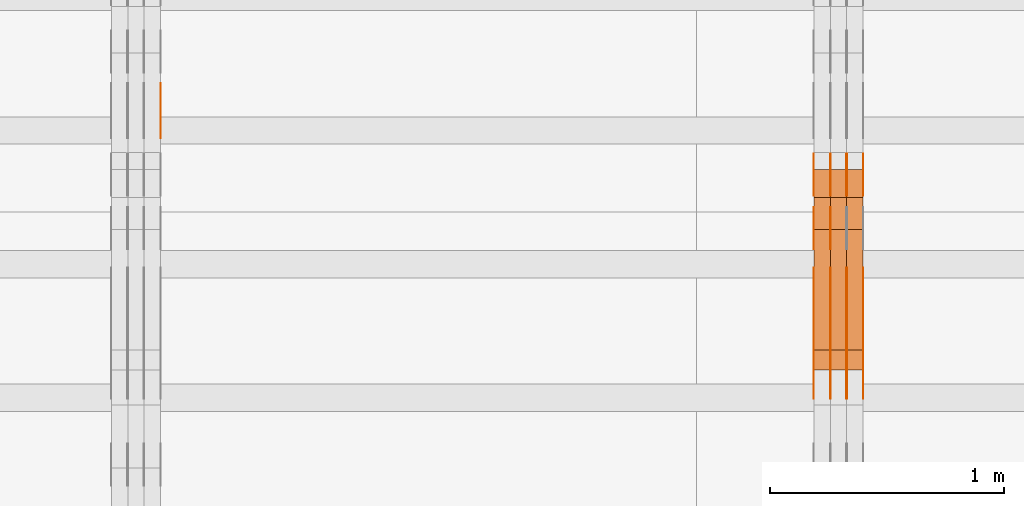
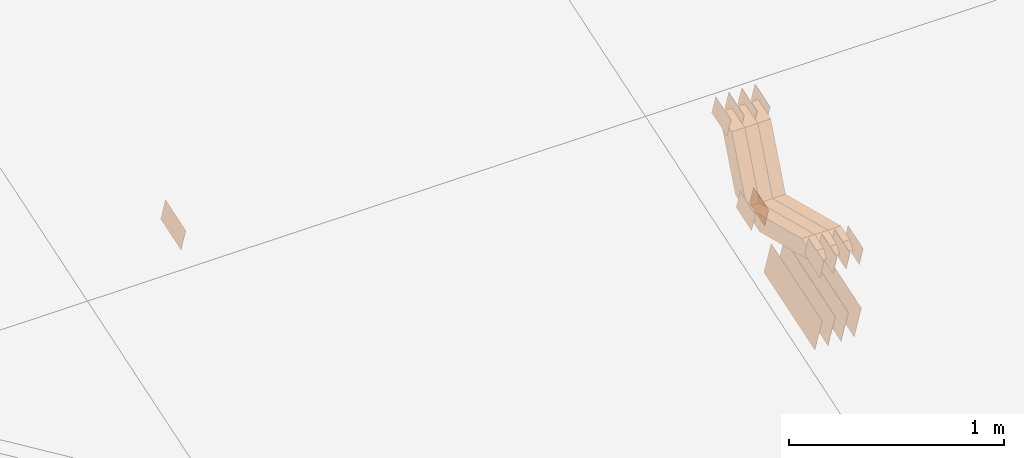
# One storey, part 259 of 385: 28 proxies.
"""IFC2X3 building model written with IfcOpenShell, lengths in millimetres."""

import ifcopenshell
import ifcopenshell.guid

model = None  # the IFC model being written
_history = None  # IfcOwnerHistory: only IFC2X3 demands one
_inside = {}  # id of a spatial element -> (the spatial element, [elements in it])
_under = {}  # id of a project, library or spatial element -> (it, [spatial elements below it])
_declared = {}  # id of a project -> (the project, [libraries it declares])
_typed = {}  # id of a type object -> (the type object, [elements of that type])
_made_of = {}  # id of a material, layer set ... -> (it, [elements and type objects made of it])


def new_model(schema):
    """Start an empty IFC model of exactly this schema.

    Asked for "IFC4X3", IfcOpenShell would pick the latest addendum, in which some entities
    have other attributes; the version numbers below select the first issue.
    IFC2X3 requires an IfcOwnerHistory on every rooted entity: one is made here for all.
    """
    global model, _history
    if schema == "IFC4X3":
        model = ifcopenshell.file(schema_version=(4, 3, 0, 0))
    else:
        model = ifcopenshell.file(schema=schema)
    _inside.clear()
    _under.clear()
    _declared.clear()
    _typed.clear()
    _made_of.clear()
    _history = None
    if model.schema == "IFC2X3":
        org = make("IfcOrganization", Name="unknown")
        user = make(
            "IfcPersonAndOrganization",
            ThePerson=make("IfcPerson", FamilyName="unknown"),
            TheOrganization=org,
        )
        app = make(
            "IfcApplication",
            ApplicationDeveloper=org,
            Version="unknown",
            ApplicationFullName="unknown",
            ApplicationIdentifier="unknown",
        )
        _history = make(
            "IfcOwnerHistory",
            OwningUser=user,
            OwningApplication=app,
            ChangeAction="ADDED",
            CreationDate=0,
        )
    return model


def make(cls, **values):
    """One entity of the class cls with the attributes given. An attribute that is None is left unset."""
    return model.create_entity(
        cls, **{name: value for name, value in values.items() if value is not None}
    )


def entity(cls, *values):
    """Any entity or typed value of the class cls, its attributes in the order of the schema. None: left unset."""
    e = model.create_entity(cls)
    for i, value in enumerate(values):
        if value is not None:
            e[i] = value
    return e


def rooted(cls, **values):
    """An entity with a GlobalId (a new one), such as an element, a storey or a relation."""
    return make(cls, GlobalId=ifcopenshell.guid.new(), OwnerHistory=_history, **values)


def si_unit(unit_type, name, prefix=None):
    """IfcSIUnit, for example si_unit("LENGTHUNIT", "METRE", prefix="MILLI")."""
    return make("IfcSIUnit", UnitType=unit_type, Prefix=prefix, Name=name)


def converted_unit(unit_type, name, factor, base, dimensions=None, offset=None):
    """IfcConversionBasedUnit, such as the inch: factor (a typed value) times the base unit."""
    return make(
        "IfcConversionBasedUnit"
        if offset is None
        else "IfcConversionBasedUnitWithOffset",
        ConversionOffset=offset,
        Dimensions=None
        if dimensions is None
        else entity("IfcDimensionalExponents", *dimensions),
        UnitType=unit_type,
        Name=name,
        ConversionFactor=make(
            "IfcMeasureWithUnit", ValueComponent=factor, UnitComponent=base
        ),
    )


def derived_unit(unit_type, elements):
    """IfcDerivedUnit: a product of units, each with its exponent."""
    return make(
        "IfcDerivedUnit",
        Elements=[
            make("IfcDerivedUnitElement", Unit=unit, Exponent=power)
            for unit, power in elements
        ],
        UnitType=unit_type,
    )


def assignment(units):
    """IfcUnitAssignment: the units of a project."""
    return None if units is None else make("IfcUnitAssignment", Units=units)


def point(xyz):
    """IfcCartesianPoint."""
    return None if xyz is None else make("IfcCartesianPoint", Coordinates=xyz)


def direction(xyz):
    """IfcDirection."""
    return None if xyz is None else make("IfcDirection", DirectionRatios=xyz)


def frame(location, z_axis=None, x_axis=None):
    """IfcAxis2Placement3D, a coordinate frame: its origin and axes. An axis left out is left unset."""
    return make(
        "IfcAxis2Placement3D",
        Location=point(location),
        Axis=direction(z_axis),
        RefDirection=direction(x_axis),
    )


def origin():
    """The frame at (0, 0, 0) with its axes left unset."""
    return frame((0.0, 0.0, 0.0))


def place(relative_to, where):
    """IfcLocalPlacement: puts the frame where relative to a parent placement (None: the world)."""
    return make(
        "IfcLocalPlacement", PlacementRelTo=relative_to, RelativePlacement=where
    )


def context(
    kind, dimensions, precision=None, world=None, true_north=None, identifier=None
):
    """IfcGeometricRepresentationContext, for example the 3D "Model" context."""
    return make(
        "IfcGeometricRepresentationContext",
        ContextIdentifier=identifier,
        ContextType=kind,
        CoordinateSpaceDimension=dimensions,
        Precision=precision,
        WorldCoordinateSystem=world,
        TrueNorth=true_north,
    )


def subcontext(parent, identifier, kind, view, scale=None):
    """IfcGeometricRepresentationSubContext, for example "Body" below "Model"."""
    return make(
        "IfcGeometricRepresentationSubContext",
        ContextIdentifier=identifier,
        ContextType=kind,
        ParentContext=parent,
        TargetScale=scale,
        TargetView=view,
    )


def project(units=None, contexts=None):
    """IfcProject with its units and contexts."""
    return rooted(
        "IfcProject",
        Name="project",
        RepresentationContexts=contexts,
        UnitsInContext=assignment(units),
    )


def spatial(cls, under=None, at=None, **own):
    """A site, building, storey or space (cls), placed at a placement, below another one or the project."""
    s = rooted(cls, ObjectPlacement=at, **own)
    if under is not None:
        _under.setdefault(under.id(), (under, []))[1].append(s)
    return s


def polyline(points):
    """IfcPolyline through the points."""
    return make("IfcPolyline", Points=[point(p) for p in points])


def outline(outer, holes=None, kind="AREA"):
    """IfcArbitraryClosedProfileDef: a profile drawn as a closed curve; with holes, ...WithVoids."""
    if holes is None:
        return make("IfcArbitraryClosedProfileDef", ProfileType=kind, OuterCurve=outer)
    return make(
        "IfcArbitraryProfileDefWithVoids",
        ProfileType=kind,
        OuterCurve=outer,
        InnerCurves=holes,
    )


def extrude(swept, where, along, depth):
    """IfcExtrudedAreaSolid: the profile swept, set in the frame where, extruded along a direction by depth."""
    return make(
        "IfcExtrudedAreaSolid",
        SweptArea=swept,
        Position=where,
        ExtrudedDirection=direction(along),
        Depth=depth,
    )


def shape(context_of_items, identifier, shape_type, items):
    """IfcShapeRepresentation: the items that make up one representation, for example the "Body"."""
    return make(
        "IfcShapeRepresentation",
        ContextOfItems=context_of_items,
        RepresentationIdentifier=identifier,
        RepresentationType=shape_type,
        Items=items,
    )


def source(mapping_origin, context_of_items, identifier, shape_type, items):
    """IfcRepresentationMap: a shape defined once, which mapped items show again and again."""
    return make(
        "IfcRepresentationMap",
        MappingOrigin=mapping_origin,
        MappedRepresentation=shape(context_of_items, identifier, shape_type, items),
    )


def transform(
    local_origin,
    x_axis=None,
    y_axis=None,
    z_axis=None,
    scale=None,
    scale2=None,
    scale3=None,
    uniform=True,
):
    """IfcCartesianTransformationOperator3D, or its non-uniform kind. x_axis, y_axis, z_axis: its Axis1, 2, 3."""
    if uniform:
        return make(
            "IfcCartesianTransformationOperator3D",
            Axis1=direction(x_axis),
            Axis2=direction(y_axis),
            LocalOrigin=point(local_origin),
            Scale=scale,
            Axis3=direction(z_axis),
        )
    return make(
        "IfcCartesianTransformationOperator3DnonUniform",
        Axis1=direction(x_axis),
        Axis2=direction(y_axis),
        LocalOrigin=point(local_origin),
        Scale=scale,
        Axis3=direction(z_axis),
        Scale2=scale2,
        Scale3=scale3,
    )


def mapped(mapping_source, mapping_target):
    """IfcMappedItem: shows the shape of a source again, moved by a transform."""
    return make(
        "IfcMappedItem", MappingSource=mapping_source, MappingTarget=mapping_target
    )


def material(Name=None, Category=None):
    """IfcMaterial."""
    return make("IfcMaterial", Name=Name, Category=Category)


def made_of(thing, what):
    """Note that an element or type object is made of a material, layer set ...; save() writes the relation."""
    if what is not None:
        _made_of.setdefault(what.id(), (what, []))[1].append(thing)
    return thing


def type_object(cls, material=None, **own):
    """A type object (cls), such as IfcWallType, which elements share."""
    return made_of(rooted(cls, **own), material)


def type_shapes(of_type, sources):
    """Give a type object the sources (RepresentationMaps) that its elements show as mapped items."""
    of_type.RepresentationMaps = sources


def element(
    cls,
    number,
    at=None,
    inside=None,
    cuts=None,
    type_object=None,
    material=None,
    context=None,
    identifier="Body",
    shape_type=None,
    held_by="IfcProductDefinitionShape",
    body=None,
    shapes=None,
    **own,
):
    """One element of the class cls, such as IfcWall. Its Tag is "e" and its number.

    at: its placement. inside: the storey or other place that contains it. cuts: it is an
    opening in that element (IfcRelVoidsElement). A single representation is given by context,
    identifier, shape_type and body (its items); several are given by shapes. held_by: the class
    of the entity that holds the representations. save() writes the other relations.
    """
    e = rooted(cls, Tag="e%d" % number, ObjectPlacement=at, **own)
    if body is not None:
        shapes = [shape(context, identifier, shape_type, body)]
    if shapes is not None:
        e.Representation = make(held_by, Representations=shapes)
    if inside is not None:
        _inside.setdefault(inside.id(), (inside, []))[1].append(e)
    if cuts is not None:
        rooted(
            "IfcRelVoidsElement", RelatingBuildingElement=cuts, RelatedOpeningElement=e
        )
    if type_object is not None:
        _typed.setdefault(type_object.id(), (type_object, []))[1].append(e)
    return made_of(e, material)


def aggregate(whole, parts):
    """IfcRelAggregates: a whole, such as a stair, and the parts it consists of."""
    return rooted("IfcRelAggregates", RelatingObject=whole, RelatedObjects=parts)


def save(model, path):
    """Write the relations noted so far, then the file.

    IfcRelAggregates (storeys below a building ...), IfcRelContainedInSpatialStructure (elements
    in a storey), IfcRelDefinesByType, IfcRelAssociatesMaterial and IfcRelDeclares: one each for
    every whole, place, type object, material and project.
    """
    for whole, parts in _under.values():
        aggregate(whole, parts)
    for where, things in _inside.values():
        rooted(
            "IfcRelContainedInSpatialStructure",
            RelatedElements=things,
            RelatingStructure=where,
        )
    for kind, things in _typed.values():
        rooted("IfcRelDefinesByType", RelatedObjects=things, RelatingType=kind)
    for what, things in _made_of.values():
        rooted("IfcRelAssociatesMaterial", RelatedObjects=things, RelatingMaterial=what)
    for by, libraries in _declared.values():
        rooted("IfcRelDeclares", RelatingContext=by, RelatedDefinitions=libraries)
    model.write(path)


model = new_model("IFC2X3")

# Units and contexts
model_context = context("Model", 3, precision=0.01, world=origin(), true_north=direction((6.12303176911189e-17, 1.0)))
body_context = subcontext(model_context, "Body", "Model", "MODEL_VIEW")
ifc_project = project(units=[si_unit("LENGTHUNIT", "METRE", prefix="MILLI"), si_unit("AREAUNIT", "SQUARE_METRE"), si_unit("VOLUMEUNIT", "CUBIC_METRE"), converted_unit("PLANEANGLEUNIT", "DEGREE", entity("IfcRatioMeasure", 0.0174532925199433), si_unit("PLANEANGLEUNIT", "RADIAN"), dimensions=[0, 0, 0, 0, 0, 0, 0]), si_unit("MASSUNIT", "GRAM", prefix="KILO"), derived_unit("MASSDENSITYUNIT", [(si_unit("MASSUNIT", "GRAM", prefix="KILO"), 1), (si_unit("LENGTHUNIT", "METRE"), -3)]), si_unit("TIMEUNIT", "SECOND"), si_unit("FREQUENCYUNIT", "HERTZ"), si_unit("THERMODYNAMICTEMPERATUREUNIT", "DEGREE_CELSIUS"), derived_unit("THERMALTRANSMITTANCEUNIT", [(si_unit("MASSUNIT", "GRAM", prefix="KILO"), 1), (si_unit("THERMODYNAMICTEMPERATUREUNIT", "KELVIN"), -1), (si_unit("TIMEUNIT", "SECOND"), -3)]), derived_unit("VOLUMETRICFLOWRATEUNIT", [(si_unit("LENGTHUNIT", "METRE"), 3), (si_unit("TIMEUNIT", "SECOND"), -1)]), si_unit("ELECTRICCURRENTUNIT", "AMPERE"), si_unit("ELECTRICVOLTAGEUNIT", "VOLT"), si_unit("POWERUNIT", "WATT"), si_unit("FORCEUNIT", "NEWTON", prefix="KILO"), si_unit("ILLUMINANCEUNIT", "LUX"), si_unit("LUMINOUSFLUXUNIT", "LUMEN"), si_unit("LUMINOUSINTENSITYUNIT", "CANDELA"), derived_unit("USERDEFINED", [(si_unit("MASSUNIT", "GRAM", prefix="KILO"), -1), (si_unit("LENGTHUNIT", "METRE"), -2), (si_unit("TIMEUNIT", "SECOND"), 3), (si_unit("LUMINOUSFLUXUNIT", "LUMEN"), 1)]), derived_unit("LINEARVELOCITYUNIT", [(si_unit("LENGTHUNIT", "METRE"), 1), (si_unit("TIMEUNIT", "SECOND"), -1)]), si_unit("PRESSUREUNIT", "PASCAL"), derived_unit("USERDEFINED", [(si_unit("LENGTHUNIT", "METRE"), -2), (si_unit("MASSUNIT", "GRAM", prefix="KILO"), 1), (si_unit("TIMEUNIT", "SECOND"), -2)])], contexts=[model_context])

# Site, building, storey
site_placement = place(None, origin())
site = spatial("IfcSite", under=ifc_project, at=site_placement, CompositionType="ELEMENT")
building_placement = place(site_placement, origin())
building = spatial("IfcBuilding", under=site, at=building_placement, CompositionType="ELEMENT")
storey_placement = place(building_placement, origin())
storey = spatial("IfcBuildingStorey", under=building, at=storey_placement, Name="Default", CompositionType="ELEMENT", Elevation=0.0)

# Proxies
ifc_material_1 = material(Name="IfcSurfaceStyle #488187")
building_element_proxy_type_1 = type_object("IfcBuildingElementProxyType", PredefinedType="NOTDEFINED", material=ifc_material_1)
shared_shape_1 = source(origin(), body_context, "Body", "SweptSolid", [
    extrude(outline(polyline([(-74.9998565677179, -60.000059685226), (74.9998794200128, -60.000059685226), (74.9998565677179, 60.000059685226), (-74.9998794200128, 60.000059685226), (-74.9998565677179, -60.000059685226)])), frame((75.0001976720505, 60.000059685226, 0.0), z_axis=(0.0, 0.0, 1.0), x_axis=(-1.0, 0.0, 0.0)), (0.0, 0.0, 1.0), 1.29999999999999),
])
type_shapes(building_element_proxy_type_1, [shared_shape_1])
proxy_1_placement = place(building_placement, frame((39245.0, 8537.53090236182, 1950.11166041942), z_axis=(-1.0, 0.0, 0.0), x_axis=(0.0, 0.951056516295124, 0.309016994375039)))
element("IfcBuildingElementProxy", 1, at=proxy_1_placement, inside=storey, type_object=building_element_proxy_type_1, material=ifc_material_1, context=body_context, shape_type="MappedRepresentation", body=[
    mapped(shared_shape_1, transform((0.0, 0.0, 0.0), scale=1.0)),
])
ifc_material_2 = material(Name="IfcSurfaceStyle #488130")
building_element_proxy_type_2 = type_object("IfcBuildingElementProxyType", PredefinedType="NOTDEFINED", material=ifc_material_2)
shared_shape_2 = source(origin(), body_context, "Body", "SweptSolid", [
    extrude(outline(polyline([(-74.9998565677179, -60.000059685226), (74.9998794200128, -60.000059685226), (74.9998565677179, 60.000059685226), (-74.9998794200128, 60.000059685226), (-74.9998565677179, -60.000059685226)])), frame((75.0001976720505, 60.000059685226, 0.0), z_axis=(0.0, 0.0, 1.0), x_axis=(-1.0, 0.0, 0.0)), (0.0, 0.0, 1.0), 1.29999999999999),
])
type_shapes(building_element_proxy_type_2, [shared_shape_2])
proxy_2_placement = place(building_placement, frame((39246.3, 8537.53090236182, 1950.11166041942), z_axis=(-1.0, 0.0, 0.0), x_axis=(0.0, 0.951056516295124, 0.309016994375039)))
element("IfcBuildingElementProxy", 2, at=proxy_2_placement, inside=storey, type_object=building_element_proxy_type_2, material=ifc_material_2, context=body_context, shape_type="MappedRepresentation", body=[
    mapped(shared_shape_2, transform((0.0, 0.0, 0.0), scale=1.0)),
])
ifc_material_3 = material(Name="IfcSurfaceStyle #488073")
building_element_proxy_type_3 = type_object("IfcBuildingElementProxyType", PredefinedType="NOTDEFINED", material=ifc_material_3)
shared_shape_3 = source(origin(), body_context, "Body", "SweptSolid", [
    extrude(outline(polyline([(-74.9998565677179, -60.000059685226), (74.9998794200128, -60.000059685226), (74.9998565677179, 60.000059685226), (-74.9998794200128, 60.000059685226), (-74.9998565677179, -60.000059685226)])), frame((75.0001976720505, 60.000059685226, 0.0), z_axis=(0.0, 0.0, 1.0), x_axis=(-1.0, 0.0, 0.0)), (0.0, 0.0, 1.0), 1.29999999999999),
])
type_shapes(building_element_proxy_type_3, [shared_shape_3])
proxy_3_placement = place(building_placement, frame((39175.0, 8537.53090236182, 1950.11166041942), z_axis=(-1.0, 0.0, 0.0), x_axis=(0.0, 0.951056516295124, 0.309016994375039)))
element("IfcBuildingElementProxy", 3, at=proxy_3_placement, inside=storey, type_object=building_element_proxy_type_3, material=ifc_material_3, context=body_context, shape_type="MappedRepresentation", body=[
    mapped(shared_shape_3, transform((0.0, 0.0, 0.0), scale=1.0)),
])
ifc_material_4 = material(Name="IfcSurfaceStyle #488016")
building_element_proxy_type_4 = type_object("IfcBuildingElementProxyType", PredefinedType="NOTDEFINED", material=ifc_material_4)
shared_shape_4 = source(origin(), body_context, "Body", "SweptSolid", [
    extrude(outline(polyline([(-74.9998754286225, -60.0000016373515), (74.9998605591045, -60.0000016373515), (74.9998754286225, 60.0000016373515), (-74.9998605591045, 60.0000016373515), (-74.9998754286225, -60.0000016373515)])), frame((74.9998754286225, 60.0000016373515, 0.0), z_axis=(0.0, 0.0, 1.0), x_axis=(-1.0, 0.0, 0.0)), (0.0, 0.0, 1.0), 1.3),
])
type_shapes(building_element_proxy_type_4, [shared_shape_4])
proxy_4_placement = place(building_placement, frame((39386.3, 8765.47458614632, 2350.86432930304), z_axis=(-1.0, 0.0, 0.0), x_axis=(0.0, 0.951056516295154, 0.309016994374948)))
element("IfcBuildingElementProxy", 4, at=proxy_4_placement, inside=storey, type_object=building_element_proxy_type_4, material=ifc_material_4, context=body_context, shape_type="MappedRepresentation", body=[
    mapped(shared_shape_4, transform((0.0, 0.0, 0.0), scale=1.0)),
])
ifc_material_5 = material(Name="IfcSurfaceStyle #487959")
building_element_proxy_type_5 = type_object("IfcBuildingElementProxyType", PredefinedType="NOTDEFINED", material=ifc_material_5)
shared_shape_5 = source(origin(), body_context, "Body", "SweptSolid", [
    extrude(outline(polyline([(-74.9998754286225, -60.0000016373515), (74.9998605591045, -60.0000016373515), (74.9998754286225, 60.0000016373515), (-74.9998605591045, 60.0000016373515), (-74.9998754286225, -60.0000016373515)])), frame((74.9998754286225, 60.0000016373515, 0.0), z_axis=(0.0, 0.0, 1.0), x_axis=(-1.0, 0.0, 0.0)), (0.0, 0.0, 1.0), 1.3),
])
type_shapes(building_element_proxy_type_5, [shared_shape_5])
proxy_5_placement = place(building_placement, frame((39315.0, 8765.47458614632, 2350.86432930304), z_axis=(-1.0, 0.0, 0.0), x_axis=(0.0, 0.951056516295154, 0.309016994374948)))
element("IfcBuildingElementProxy", 5, at=proxy_5_placement, inside=storey, type_object=building_element_proxy_type_5, material=ifc_material_5, context=body_context, shape_type="MappedRepresentation", body=[
    mapped(shared_shape_5, transform((0.0, 0.0, 0.0), scale=1.0)),
])
ifc_material_6 = material(Name="IfcSurfaceStyle #487902")
building_element_proxy_type_6 = type_object("IfcBuildingElementProxyType", PredefinedType="NOTDEFINED", material=ifc_material_6)
shared_shape_6 = source(origin(), body_context, "Body", "SweptSolid", [
    extrude(outline(polyline([(-74.9998754286225, -60.0000016373515), (74.9998605591045, -60.0000016373515), (74.9998754286225, 60.0000016373515), (-74.9998605591045, 60.0000016373515), (-74.9998754286225, -60.0000016373515)])), frame((74.9998754286225, 60.0000016373515, 0.0), z_axis=(0.0, 0.0, 1.0), x_axis=(-1.0, 0.0, 0.0)), (0.0, 0.0, 1.0), 1.3),
])
type_shapes(building_element_proxy_type_6, [shared_shape_6])
proxy_6_placement = place(building_placement, frame((39316.3, 8765.47458614632, 2350.86432930304), z_axis=(-1.0, 0.0, 0.0), x_axis=(0.0, 0.951056516295154, 0.309016994374948)))
element("IfcBuildingElementProxy", 6, at=proxy_6_placement, inside=storey, type_object=building_element_proxy_type_6, material=ifc_material_6, context=body_context, shape_type="MappedRepresentation", body=[
    mapped(shared_shape_6, transform((0.0, 0.0, 0.0), scale=1.0)),
])
ifc_material_7 = material(Name="IfcSurfaceStyle #487845")
building_element_proxy_type_7 = type_object("IfcBuildingElementProxyType", PredefinedType="NOTDEFINED", material=ifc_material_7)
shared_shape_7 = source(origin(), body_context, "Body", "SweptSolid", [
    extrude(outline(polyline([(-74.9998754286225, -60.0000016373515), (74.9998605591045, -60.0000016373515), (74.9998754286225, 60.0000016373515), (-74.9998605591045, 60.0000016373515), (-74.9998754286225, -60.0000016373515)])), frame((74.9998754286225, 60.0000016373515, 0.0), z_axis=(0.0, 0.0, 1.0), x_axis=(-1.0, 0.0, 0.0)), (0.0, 0.0, 1.0), 1.29999999999999),
])
type_shapes(building_element_proxy_type_7, [shared_shape_7])
proxy_7_placement = place(building_placement, frame((39245.0, 8765.47458614632, 2350.86432930304), z_axis=(-1.0, 0.0, 0.0), x_axis=(0.0, 0.951056516295154, 0.309016994374948)))
element("IfcBuildingElementProxy", 7, at=proxy_7_placement, inside=storey, type_object=building_element_proxy_type_7, material=ifc_material_7, context=body_context, shape_type="MappedRepresentation", body=[
    mapped(shared_shape_7, transform((0.0, 0.0, 0.0), scale=1.0)),
])
ifc_material_8 = material(Name="IfcSurfaceStyle #487788")
building_element_proxy_type_8 = type_object("IfcBuildingElementProxyType", PredefinedType="NOTDEFINED", material=ifc_material_8)
shared_shape_8 = source(origin(), body_context, "Body", "SweptSolid", [
    extrude(outline(polyline([(-74.9998754286225, -60.0000016373515), (74.9998605591045, -60.0000016373515), (74.9998754286225, 60.0000016373515), (-74.9998605591045, 60.0000016373515), (-74.9998754286225, -60.0000016373515)])), frame((74.9998754286225, 60.0000016373515, 0.0), z_axis=(0.0, 0.0, 1.0), x_axis=(-1.0, 0.0, 0.0)), (0.0, 0.0, 1.0), 1.29999999999999),
])
type_shapes(building_element_proxy_type_8, [shared_shape_8])
proxy_8_placement = place(building_placement, frame((39246.3, 8765.47458614632, 2350.86432930304), z_axis=(-1.0, 0.0, 0.0), x_axis=(0.0, 0.951056516295154, 0.309016994374948)))
element("IfcBuildingElementProxy", 8, at=proxy_8_placement, inside=storey, type_object=building_element_proxy_type_8, material=ifc_material_8, context=body_context, shape_type="MappedRepresentation", body=[
    mapped(shared_shape_8, transform((0.0, 0.0, 0.0), scale=1.0)),
])
ifc_material_9 = material(Name="IfcSurfaceStyle #487731")
building_element_proxy_type_9 = type_object("IfcBuildingElementProxyType", PredefinedType="NOTDEFINED", material=ifc_material_9)
shared_shape_9 = source(origin(), body_context, "Body", "SweptSolid", [
    extrude(outline(polyline([(-74.9998754286225, -60.0000016373515), (74.9998605591045, -60.0000016373515), (74.9998754286225, 60.0000016373515), (-74.9998605591045, 60.0000016373515), (-74.9998754286225, -60.0000016373515)])), frame((74.9998754286225, 60.0000016373515, 0.0), z_axis=(0.0, 0.0, 1.0), x_axis=(-1.0, 0.0, 0.0)), (0.0, 0.0, 1.0), 1.29999999999999),
])
type_shapes(building_element_proxy_type_9, [shared_shape_9])
proxy_9_placement = place(building_placement, frame((39175.0, 8765.47458614632, 2350.86432930304), z_axis=(-1.0, 0.0, 0.0), x_axis=(0.0, 0.951056516295154, 0.309016994374948)))
element("IfcBuildingElementProxy", 9, at=proxy_9_placement, inside=storey, type_object=building_element_proxy_type_9, material=ifc_material_9, context=body_context, shape_type="MappedRepresentation", body=[
    mapped(shared_shape_9, transform((0.0, 0.0, 0.0), scale=1.0)),
])
ifc_material_10 = material(Name="IfcSurfaceStyle #487332")
building_element_proxy_type_10 = type_object("IfcBuildingElementProxyType", PredefinedType="NOTDEFINED", material=ifc_material_10)
shared_shape_10 = source(origin(), body_context, "Body", "SweptSolid", [
    extrude(outline(polyline([(-249.999749056184, -108.000229288163), (249.999396050782, -108.000229288163), (249.999749056184, 108.000229288163), (-249.999396050782, 108.000229288163), (-249.999749056184, -108.000229288163)])), frame((249.999841104007, 108.000229288163, 0.0), z_axis=(0.0, 0.0, 1.0), x_axis=(-1.0, 0.0, 0.0)), (0.0, 0.0, 1.0), 1.29999999999998),
])
type_shapes(building_element_proxy_type_10, [shared_shape_10])
proxy_10_placement = place(building_placement, frame((39386.3, 7917.13457673635, 1720.66532252899), z_axis=(-1.0, 0.0, 0.0), x_axis=(0.0, 0.951056516295124, 0.309016994375039)))
element("IfcBuildingElementProxy", 10, at=proxy_10_placement, inside=storey, type_object=building_element_proxy_type_10, material=ifc_material_10, context=body_context, shape_type="MappedRepresentation", body=[
    mapped(shared_shape_10, transform((0.0, 0.0, 0.0), scale=1.0)),
])
ifc_material_11 = material(Name="IfcSurfaceStyle #487275")
building_element_proxy_type_11 = type_object("IfcBuildingElementProxyType", PredefinedType="NOTDEFINED", material=ifc_material_11)
shared_shape_11 = source(origin(), body_context, "Body", "SweptSolid", [
    extrude(outline(polyline([(-249.999749056184, -108.000229288163), (249.999396050782, -108.000229288163), (249.999749056184, 108.000229288163), (-249.999396050782, 108.000229288163), (-249.999749056184, -108.000229288163)])), frame((249.999841104007, 108.000229288163, 0.0), z_axis=(0.0, 0.0, 1.0), x_axis=(-1.0, 0.0, 0.0)), (0.0, 0.0, 1.0), 1.29999999999998),
])
type_shapes(building_element_proxy_type_11, [shared_shape_11])
proxy_11_placement = place(building_placement, frame((39315.0, 7917.13457673635, 1720.66532252899), z_axis=(-1.0, 0.0, 0.0), x_axis=(0.0, 0.951056516295124, 0.309016994375039)))
element("IfcBuildingElementProxy", 11, at=proxy_11_placement, inside=storey, type_object=building_element_proxy_type_11, material=ifc_material_11, context=body_context, shape_type="MappedRepresentation", body=[
    mapped(shared_shape_11, transform((0.0, 0.0, 0.0), scale=1.0)),
])
ifc_material_12 = material(Name="IfcSurfaceStyle #487218")
building_element_proxy_type_12 = type_object("IfcBuildingElementProxyType", PredefinedType="NOTDEFINED", material=ifc_material_12)
shared_shape_12 = source(origin(), body_context, "Body", "SweptSolid", [
    extrude(outline(polyline([(-249.999749056184, -108.000229288163), (249.999396050782, -108.000229288163), (249.999749056184, 108.000229288163), (-249.999396050782, 108.000229288163), (-249.999749056184, -108.000229288163)])), frame((249.999841104007, 108.000229288163, 0.0), z_axis=(0.0, 0.0, 1.0), x_axis=(-1.0, 0.0, 0.0)), (0.0, 0.0, 1.0), 1.29999999999998),
])
type_shapes(building_element_proxy_type_12, [shared_shape_12])
proxy_12_placement = place(building_placement, frame((39316.3, 7917.13457673635, 1720.66532252899), z_axis=(-1.0, 0.0, 0.0), x_axis=(0.0, 0.951056516295124, 0.309016994375039)))
element("IfcBuildingElementProxy", 12, at=proxy_12_placement, inside=storey, type_object=building_element_proxy_type_12, material=ifc_material_12, context=body_context, shape_type="MappedRepresentation", body=[
    mapped(shared_shape_12, transform((0.0, 0.0, 0.0), scale=1.0)),
])
ifc_material_13 = material(Name="IfcSurfaceStyle #487161")
building_element_proxy_type_13 = type_object("IfcBuildingElementProxyType", PredefinedType="NOTDEFINED", material=ifc_material_13)
shared_shape_13 = source(origin(), body_context, "Body", "SweptSolid", [
    extrude(outline(polyline([(-249.999749056184, -108.000229288163), (249.999396050782, -108.000229288163), (249.999749056184, 108.000229288163), (-249.999396050782, 108.000229288163), (-249.999749056184, -108.000229288163)])), frame((249.999841104007, 108.000229288163, 0.0), z_axis=(0.0, 0.0, 1.0), x_axis=(-1.0, 0.0, 0.0)), (0.0, 0.0, 1.0), 1.29999999999997),
])
type_shapes(building_element_proxy_type_13, [shared_shape_13])
proxy_13_placement = place(building_placement, frame((39245.0, 7917.13457673635, 1720.66532252899), z_axis=(-1.0, 0.0, 0.0), x_axis=(0.0, 0.951056516295124, 0.309016994375039)))
element("IfcBuildingElementProxy", 13, at=proxy_13_placement, inside=storey, type_object=building_element_proxy_type_13, material=ifc_material_13, context=body_context, shape_type="MappedRepresentation", body=[
    mapped(shared_shape_13, transform((0.0, 0.0, 0.0), scale=1.0)),
])
ifc_material_14 = material(Name="IfcSurfaceStyle #487104")
building_element_proxy_type_14 = type_object("IfcBuildingElementProxyType", PredefinedType="NOTDEFINED", material=ifc_material_14)
shared_shape_14 = source(origin(), body_context, "Body", "SweptSolid", [
    extrude(outline(polyline([(-249.999749056184, -108.000229288163), (249.999396050782, -108.000229288163), (249.999749056184, 108.000229288163), (-249.999396050782, 108.000229288163), (-249.999749056184, -108.000229288163)])), frame((249.999841104007, 108.000229288163, 0.0), z_axis=(0.0, 0.0, 1.0), x_axis=(-1.0, 0.0, 0.0)), (0.0, 0.0, 1.0), 1.29999999999997),
])
type_shapes(building_element_proxy_type_14, [shared_shape_14])
proxy_14_placement = place(building_placement, frame((39246.3, 7917.13457673635, 1720.66532252899), z_axis=(-1.0, 0.0, 0.0), x_axis=(0.0, 0.951056516295124, 0.309016994375039)))
element("IfcBuildingElementProxy", 14, at=proxy_14_placement, inside=storey, type_object=building_element_proxy_type_14, material=ifc_material_14, context=body_context, shape_type="MappedRepresentation", body=[
    mapped(shared_shape_14, transform((0.0, 0.0, 0.0), scale=1.0)),
])
ifc_material_15 = material(Name="IfcSurfaceStyle #487047")
building_element_proxy_type_15 = type_object("IfcBuildingElementProxyType", PredefinedType="NOTDEFINED", material=ifc_material_15)
shared_shape_15 = source(origin(), body_context, "Body", "SweptSolid", [
    extrude(outline(polyline([(-249.999749056184, -108.000229288163), (249.999396050782, -108.000229288163), (249.999749056184, 108.000229288163), (-249.999396050782, 108.000229288163), (-249.999749056184, -108.000229288163)])), frame((249.999841104007, 108.000229288163, 0.0), z_axis=(0.0, 0.0, 1.0), x_axis=(-1.0, 0.0, 0.0)), (0.0, 0.0, 1.0), 1.29999999999997),
])
type_shapes(building_element_proxy_type_15, [shared_shape_15])
proxy_15_placement = place(building_placement, frame((39175.0, 7917.13457673635, 1720.66532252899), z_axis=(-1.0, 0.0, 0.0), x_axis=(0.0, 0.951056516295124, 0.309016994375039)))
element("IfcBuildingElementProxy", 15, at=proxy_15_placement, inside=storey, type_object=building_element_proxy_type_15, material=ifc_material_15, context=body_context, shape_type="MappedRepresentation", body=[
    mapped(shared_shape_15, transform((0.0, 0.0, 0.0), scale=1.0)),
])
ifc_material_16 = material(Name="IfcSurfaceStyle #473652")
building_element_proxy_type_16 = type_object("IfcBuildingElementProxyType", PredefinedType="NOTDEFINED", material=ifc_material_16)
shared_shape_16 = source(origin(), body_context, "Body", "SweptSolid", [
    extrude(outline(polyline([(-74.9998754286253, -60.0000016373506), (74.9998605591091, -60.0000016373506), (74.9998754286234, 60.0000016373506), (-74.9998605591072, 60.0000016373506), (-74.9998754286253, -60.0000016373506)])), frame((75.0007355357002, 60.0002637031812, 0.0), z_axis=(0.0, 0.0, 1.0), x_axis=(-1.0, 0.0, 0.0)), (0.0, 0.0, 1.0), 1.3),
])
type_shapes(building_element_proxy_type_16, [shared_shape_16])
proxy_16_placement = place(building_placement, frame((39386.3, 7899.79204652809, 2069.58672486412), z_axis=(-1.0, 0.0, 0.0), x_axis=(0.0, 0.951056516295154, 0.309016994374948)))
element("IfcBuildingElementProxy", 16, at=proxy_16_placement, inside=storey, type_object=building_element_proxy_type_16, material=ifc_material_16, context=body_context, shape_type="MappedRepresentation", body=[
    mapped(shared_shape_16, transform((0.0, 0.0, 0.0), scale=1.0)),
])
ifc_material_17 = material(Name="IfcSurfaceStyle #473595")
building_element_proxy_type_17 = type_object("IfcBuildingElementProxyType", PredefinedType="NOTDEFINED", material=ifc_material_17)
shared_shape_17 = source(origin(), body_context, "Body", "SweptSolid", [
    extrude(outline(polyline([(-74.9998754286253, -60.0000016373506), (74.9998605591091, -60.0000016373506), (74.9998754286234, 60.0000016373506), (-74.9998605591072, 60.0000016373506), (-74.9998754286253, -60.0000016373506)])), frame((75.0007355357002, 60.0002637031812, 0.0), z_axis=(0.0, 0.0, 1.0), x_axis=(-1.0, 0.0, 0.0)), (0.0, 0.0, 1.0), 1.3),
])
type_shapes(building_element_proxy_type_17, [shared_shape_17])
proxy_17_placement = place(building_placement, frame((39315.0, 7899.79204652809, 2069.58672486412), z_axis=(-1.0, 0.0, 0.0), x_axis=(0.0, 0.951056516295154, 0.309016994374948)))
element("IfcBuildingElementProxy", 17, at=proxy_17_placement, inside=storey, type_object=building_element_proxy_type_17, material=ifc_material_17, context=body_context, shape_type="MappedRepresentation", body=[
    mapped(shared_shape_17, transform((0.0, 0.0, 0.0), scale=1.0)),
])
ifc_material_18 = material(Name="IfcSurfaceStyle #473538")
building_element_proxy_type_18 = type_object("IfcBuildingElementProxyType", PredefinedType="NOTDEFINED", material=ifc_material_18)
shared_shape_18 = source(origin(), body_context, "Body", "SweptSolid", [
    extrude(outline(polyline([(-74.9998754286253, -60.0000016373506), (74.9998605591091, -60.0000016373506), (74.9998754286234, 60.0000016373506), (-74.9998605591072, 60.0000016373506), (-74.9998754286253, -60.0000016373506)])), frame((75.0007355357002, 60.0002637031812, 0.0), z_axis=(0.0, 0.0, 1.0), x_axis=(-1.0, 0.0, 0.0)), (0.0, 0.0, 1.0), 1.3),
])
type_shapes(building_element_proxy_type_18, [shared_shape_18])
proxy_18_placement = place(building_placement, frame((39316.3, 7899.79204652809, 2069.58672486412), z_axis=(-1.0, 0.0, 0.0), x_axis=(0.0, 0.951056516295154, 0.309016994374948)))
element("IfcBuildingElementProxy", 18, at=proxy_18_placement, inside=storey, type_object=building_element_proxy_type_18, material=ifc_material_18, context=body_context, shape_type="MappedRepresentation", body=[
    mapped(shared_shape_18, transform((0.0, 0.0, 0.0), scale=1.0)),
])
ifc_material_19 = material(Name="IfcSurfaceStyle #473481")
building_element_proxy_type_19 = type_object("IfcBuildingElementProxyType", PredefinedType="NOTDEFINED", material=ifc_material_19)
shared_shape_19 = source(origin(), body_context, "Body", "SweptSolid", [
    extrude(outline(polyline([(-74.9998754286253, -60.0000016373506), (74.9998605591091, -60.0000016373506), (74.9998754286234, 60.0000016373506), (-74.9998605591072, 60.0000016373506), (-74.9998754286253, -60.0000016373506)])), frame((75.0007355357002, 60.0002637031812, 0.0), z_axis=(0.0, 0.0, 1.0), x_axis=(-1.0, 0.0, 0.0)), (0.0, 0.0, 1.0), 1.29999999999999),
])
type_shapes(building_element_proxy_type_19, [shared_shape_19])
proxy_19_placement = place(building_placement, frame((39245.0, 7899.79204652809, 2069.58672486412), z_axis=(-1.0, 0.0, 0.0), x_axis=(0.0, 0.951056516295154, 0.309016994374948)))
element("IfcBuildingElementProxy", 19, at=proxy_19_placement, inside=storey, type_object=building_element_proxy_type_19, material=ifc_material_19, context=body_context, shape_type="MappedRepresentation", body=[
    mapped(shared_shape_19, transform((0.0, 0.0, 0.0), scale=1.0)),
])
ifc_material_20 = material(Name="IfcSurfaceStyle #473424")
building_element_proxy_type_20 = type_object("IfcBuildingElementProxyType", PredefinedType="NOTDEFINED", material=ifc_material_20)
shared_shape_20 = source(origin(), body_context, "Body", "SweptSolid", [
    extrude(outline(polyline([(-74.9998754286253, -60.0000016373506), (74.9998605591091, -60.0000016373506), (74.9998754286234, 60.0000016373506), (-74.9998605591072, 60.0000016373506), (-74.9998754286253, -60.0000016373506)])), frame((75.0007355357002, 60.0002637031812, 0.0), z_axis=(0.0, 0.0, 1.0), x_axis=(-1.0, 0.0, 0.0)), (0.0, 0.0, 1.0), 1.29999999999999),
])
type_shapes(building_element_proxy_type_20, [shared_shape_20])
proxy_20_placement = place(building_placement, frame((39246.3, 7899.79204652809, 2069.58672486412), z_axis=(-1.0, 0.0, 0.0), x_axis=(0.0, 0.951056516295154, 0.309016994374948)))
element("IfcBuildingElementProxy", 20, at=proxy_20_placement, inside=storey, type_object=building_element_proxy_type_20, material=ifc_material_20, context=body_context, shape_type="MappedRepresentation", body=[
    mapped(shared_shape_20, transform((0.0, 0.0, 0.0), scale=1.0)),
])
ifc_material_21 = material(Name="IfcSurfaceStyle #473367")
building_element_proxy_type_21 = type_object("IfcBuildingElementProxyType", PredefinedType="NOTDEFINED", material=ifc_material_21)
shared_shape_21 = source(origin(), body_context, "Body", "SweptSolid", [
    extrude(outline(polyline([(-74.9998754286253, -60.0000016373506), (74.9998605591091, -60.0000016373506), (74.9998754286234, 60.0000016373506), (-74.9998605591072, 60.0000016373506), (-74.9998754286253, -60.0000016373506)])), frame((75.0007355357002, 60.0002637031812, 0.0), z_axis=(0.0, 0.0, 1.0), x_axis=(-1.0, 0.0, 0.0)), (0.0, 0.0, 1.0), 1.29999999999999),
])
type_shapes(building_element_proxy_type_21, [shared_shape_21])
proxy_21_placement = place(building_placement, frame((39175.0, 7899.79204652809, 2069.58672486412), z_axis=(-1.0, 0.0, 0.0), x_axis=(0.0, 0.951056516295154, 0.309016994374948)))
element("IfcBuildingElementProxy", 21, at=proxy_21_placement, inside=storey, type_object=building_element_proxy_type_21, material=ifc_material_21, context=body_context, shape_type="MappedRepresentation", body=[
    mapped(shared_shape_21, transform((0.0, 0.0, 0.0), scale=1.0)),
])
ifc_material_22 = material(Name="IfcSurfaceStyle #461268")
building_element_proxy_type_22 = type_object("IfcBuildingElementProxyType", Name="T1-W45 461266", PredefinedType="NOTDEFINED", material=ifc_material_22)
shared_shape_22 = source(origin(), body_context, "Body", "SweptSolid", [
    extrude(outline(polyline([(-275.953018340717, -47.500197738425), (128.971267956636, -47.5001977384251), (168.669977842085, -0.000132525443043008), (174.867371111815, 47.5002640011466), (-196.55559856982, 47.5002640011466), (-275.953018340717, -47.500197738425)])), frame((174.867371111815, 47.5002640011466, 0.0), z_axis=(0.0, 0.0, 1.0), x_axis=(-1.0, 0.0, 0.0)), (0.0, 0.0, 1.0), 70.0),
])
type_shapes(building_element_proxy_type_22, [shared_shape_22])
proxy_22_placement = place(building_placement, frame((39385.0, 8621.494140625, 1941.33422851563), z_axis=(-1.0, 0.0, 0.0), x_axis=(0.0, 0.372787901688292, 0.927916580493549)))
element("IfcBuildingElementProxy", 22, at=proxy_22_placement, inside=storey, type_object=building_element_proxy_type_22, material=ifc_material_22, Name="T1-W45", context=body_context, shape_type="MappedRepresentation", body=[
    mapped(shared_shape_22, transform((0.0, 0.0, 0.0), scale=1.0)),
])
ifc_material_23 = material(Name="IfcSurfaceStyle #461202")
building_element_proxy_type_23 = type_object("IfcBuildingElementProxyType", Name="T1-W45 461200", PredefinedType="NOTDEFINED", material=ifc_material_23)
shared_shape_23 = source(origin(), body_context, "Body", "SweptSolid", [
    extrude(outline(polyline([(-275.953018340717, -47.500197738425), (128.971267956636, -47.5001977384251), (168.669977842085, -0.000132525443043008), (174.867371111815, 47.5002640011466), (-196.55559856982, 47.5002640011466), (-275.953018340717, -47.500197738425)])), frame((174.867371111815, 47.5002640011466, 0.0), z_axis=(0.0, 0.0, 1.0), x_axis=(-1.0, 0.0, 0.0)), (0.0, 0.0, 1.0), 70.0),
])
type_shapes(building_element_proxy_type_23, [shared_shape_23])
proxy_23_placement = place(building_placement, frame((39315.0, 8621.494140625, 1941.33422851563), z_axis=(-1.0, 0.0, 0.0), x_axis=(0.0, 0.372787901688292, 0.927916580493549)))
element("IfcBuildingElementProxy", 23, at=proxy_23_placement, inside=storey, type_object=building_element_proxy_type_23, material=ifc_material_23, Name="T1-W45", context=body_context, shape_type="MappedRepresentation", body=[
    mapped(shared_shape_23, transform((0.0, 0.0, 0.0), scale=1.0)),
])
ifc_material_24 = material(Name="IfcSurfaceStyle #461136")
building_element_proxy_type_24 = type_object("IfcBuildingElementProxyType", Name="T1-W45 461134", PredefinedType="NOTDEFINED", material=ifc_material_24)
shared_shape_24 = source(origin(), body_context, "Body", "SweptSolid", [
    extrude(outline(polyline([(-275.953018340717, -47.500197738425), (128.971267956636, -47.5001977384251), (168.669977842085, -0.000132525443043008), (174.867371111815, 47.5002640011466), (-196.55559856982, 47.5002640011466), (-275.953018340717, -47.500197738425)])), frame((174.867371111815, 47.5002640011466, 0.0), z_axis=(0.0, 0.0, 1.0), x_axis=(-1.0, 0.0, 0.0)), (0.0, 0.0, 1.0), 70.0),
])
type_shapes(building_element_proxy_type_24, [shared_shape_24])
proxy_24_placement = place(building_placement, frame((39245.0, 8621.494140625, 1941.33422851563), z_axis=(-1.0, 0.0, 0.0), x_axis=(0.0, 0.372787901688292, 0.927916580493549)))
element("IfcBuildingElementProxy", 24, at=proxy_24_placement, inside=storey, type_object=building_element_proxy_type_24, material=ifc_material_24, Name="T1-W45", context=body_context, shape_type="MappedRepresentation", body=[
    mapped(shared_shape_24, transform((0.0, 0.0, 0.0), scale=1.0)),
])
ifc_material_25 = material(Name="IfcSurfaceStyle #460872")
building_element_proxy_type_25 = type_object("IfcBuildingElementProxyType", Name="T1-W11 460870", PredefinedType="NOTDEFINED", material=ifc_material_25)
shared_shape_25 = source(origin(), body_context, "Body", "SweptSolid", [
    extrude(outline(polyline([(-261.366417792209, -47.5000378467523), (260.949520182121, -47.5000378467523), (242.928845159301, -7.41559889341215e-06), (168.237407166939, 47.5000415545517), (-410.749354716152, 47.5000415545517), (-261.366417792209, -47.5000378467523)])), frame((260.949520182121, 47.5000415545517, 0.0), z_axis=(0.0, 0.0, 1.0), x_axis=(-1.0, 0.0, 0.0)), (0.0, 0.0, 1.0), 70.0),
])
type_shapes(building_element_proxy_type_25, [shared_shape_25])
proxy_25_placement = place(building_placement, frame((39385.0, 8017.44318793234, 2097.03832883996), z_axis=(-1.0, 0.0, 0.0), x_axis=(0.0, 0.968347201599873, -0.249607085543851)))
element("IfcBuildingElementProxy", 25, at=proxy_25_placement, inside=storey, type_object=building_element_proxy_type_25, material=ifc_material_25, Name="T1-W11", context=body_context, shape_type="MappedRepresentation", body=[
    mapped(shared_shape_25, transform((0.0, 0.0, 0.0), scale=1.0)),
])
ifc_material_26 = material(Name="IfcSurfaceStyle #460806")
building_element_proxy_type_26 = type_object("IfcBuildingElementProxyType", Name="T1-W11 460804", PredefinedType="NOTDEFINED", material=ifc_material_26)
shared_shape_26 = source(origin(), body_context, "Body", "SweptSolid", [
    extrude(outline(polyline([(-261.366417792209, -47.5000378467523), (260.949520182121, -47.5000378467523), (242.928845159301, -7.41559889341215e-06), (168.237407166939, 47.5000415545517), (-410.749354716152, 47.5000415545517), (-261.366417792209, -47.5000378467523)])), frame((260.949520182121, 47.5000415545517, 0.0), z_axis=(0.0, 0.0, 1.0), x_axis=(-1.0, 0.0, 0.0)), (0.0, 0.0, 1.0), 70.0),
])
type_shapes(building_element_proxy_type_26, [shared_shape_26])
proxy_26_placement = place(building_placement, frame((39315.0, 8017.44318793234, 2097.03832883996), z_axis=(-1.0, 0.0, 0.0), x_axis=(0.0, 0.968347201599873, -0.249607085543851)))
element("IfcBuildingElementProxy", 26, at=proxy_26_placement, inside=storey, type_object=building_element_proxy_type_26, material=ifc_material_26, Name="T1-W11", context=body_context, shape_type="MappedRepresentation", body=[
    mapped(shared_shape_26, transform((0.0, 0.0, 0.0), scale=1.0)),
])
ifc_material_27 = material(Name="IfcSurfaceStyle #460740")
building_element_proxy_type_27 = type_object("IfcBuildingElementProxyType", Name="T1-W11 460738", PredefinedType="NOTDEFINED", material=ifc_material_27)
shared_shape_27 = source(origin(), body_context, "Body", "SweptSolid", [
    extrude(outline(polyline([(-261.366417792209, -47.5000378467523), (260.949520182121, -47.5000378467523), (242.928845159301, -7.41559889341215e-06), (168.237407166939, 47.5000415545517), (-410.749354716152, 47.5000415545517), (-261.366417792209, -47.5000378467523)])), frame((260.949520182121, 47.5000415545517, 0.0), z_axis=(0.0, 0.0, 1.0), x_axis=(-1.0, 0.0, 0.0)), (0.0, 0.0, 1.0), 70.0),
])
type_shapes(building_element_proxy_type_27, [shared_shape_27])
proxy_27_placement = place(building_placement, frame((39245.0, 8017.44318793234, 2097.03832883996), z_axis=(-1.0, 0.0, 0.0), x_axis=(0.0, 0.968347201599873, -0.249607085543851)))
element("IfcBuildingElementProxy", 27, at=proxy_27_placement, inside=storey, type_object=building_element_proxy_type_27, material=ifc_material_27, Name="T1-W11", context=body_context, shape_type="MappedRepresentation", body=[
    mapped(shared_shape_27, transform((0.0, 0.0, 0.0), scale=1.0)),
])
ifc_material_28 = material(Name="IfcSurfaceStyle #452558")
building_element_proxy_type_28 = type_object("IfcBuildingElementProxyType", PredefinedType="NOTDEFINED", material=ifc_material_28)
shared_shape_28 = source(origin(), body_context, "Body", "SweptSolid", [
    extrude(outline(polyline([(-99.999644645517, -72.0000317581407), (100.000028485991, -72.0000317581407), (99.999644645517, 72.0000317581407), (-100.000028485991, 72.0000317581407), (-99.999644645517, -72.0000317581407)])), frame((100.000028485991, 72.0000317581407, 0.0), z_axis=(0.0, 0.0, 1.0), x_axis=(-1.0, 0.0, 0.0)), (0.0, 0.0, 1.0), 1.3),
])
type_shapes(building_element_proxy_type_28, [shared_shape_28])
proxy_28_placement = place(building_placement, frame((36386.3, 9012.6304394324, 2546.30522609783), z_axis=(-1.0, 0.0, 0.0), x_axis=(0.0, 0.951056516295154, 0.309016994374948)))
element("IfcBuildingElementProxy", 28, at=proxy_28_placement, inside=storey, type_object=building_element_proxy_type_28, material=ifc_material_28, context=body_context, shape_type="MappedRepresentation", body=[
    mapped(shared_shape_28, transform((0.0, 0.0, 0.0), scale=1.0)),
])

save(model, "model.ifc")
